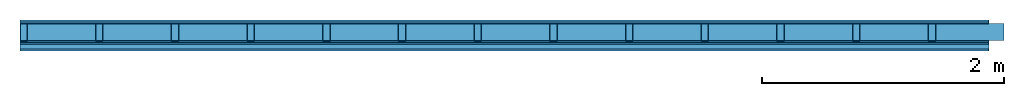
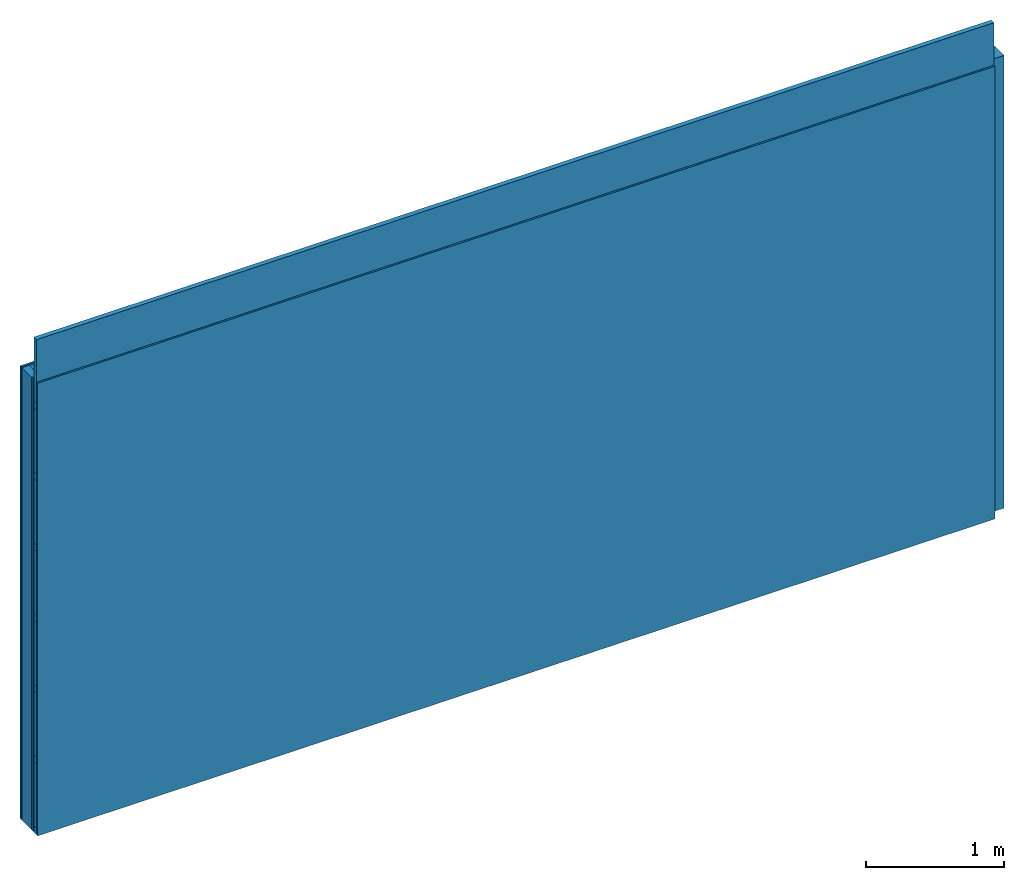
# One storey: 5 plates, 4 members, 1 element without a shape of its own.
"""IFC4 building model written with IfcOpenShell, lengths in metres."""

from ifc_helpers import new_model, si_unit, derived_unit, direction, frame, frame_2d, origin, origin_with_axes, place, context, project, spatial, rectangle, extrude, material, layer, layer_set, type_object, element, aggregate, save


model = new_model("IFC4")

# Units and contexts
plan_context = context("Plan", 3, precision=1e-05, world=origin(), true_north=direction((0.0, 1.0)))
model_context = context("Model", 3, precision=1e-05, world=origin(), true_north=direction((0.0, 1.0)))
ifc_project = project(units=[si_unit("LENGTHUNIT", "METRE"), derived_unit("SOUNDPRESSUREUNIT", [(si_unit("PRESSUREUNIT", "PASCAL", prefix="MICRO"), 0)]), si_unit("ENERGYUNIT", "JOULE", prefix="MEGA"), si_unit("MASSUNIT", "GRAM", prefix="KILO"), derived_unit("THERMALTRANSMITTANCEUNIT", [(si_unit("POWERUNIT", "WATT"), 1), (si_unit("AREAUNIT", "SQUARE_METRE"), -1), (si_unit("THERMODYNAMICTEMPERATUREUNIT", "KELVIN"), -1)]), derived_unit("AREADENSITYUNIT", [(si_unit("MASSUNIT", "GRAM", prefix="KILO"), 1), (si_unit("AREAUNIT", "SQUARE_METRE"), -1)]), derived_unit("USERDEFINED", [(si_unit("ENERGYUNIT", "JOULE", prefix="MEGA"), 1), (si_unit("AREAUNIT", "SQUARE_METRE"), -1)])], contexts=[plan_context, model_context])

# Site, building, storey
site = spatial("IfcSite", under=ifc_project)
building_placement = place(None, origin())
building = spatial("IfcBuilding", under=site, at=building_placement)
storey_placement = place(building_placement, origin())
storey = spatial("IfcBuildingStorey", under=building, at=storey_placement)

# Wall, members, plates
ifc_material_1 = material(Name="Glued joints")
ifc_layer_1 = layer(ifc_material_1, 0.0, Name="Surface")
ifc_material_2 = material(Category="03.007")
ifc_layer_2 = layer(ifc_material_2, 0.015, Name="2nd layer")
ifc_layer_3 = layer(ifc_material_2, 0.015, Name="1st layer")
ifc_material_3 = material(Name="of the art")
ifc_layer_4 = layer(ifc_material_3, 0.0, Name="Bond")
ifc_layer_5 = layer(None, 0.14, Name="Support")
ifc_layer_6 = layer(ifc_material_3, 0.0, Name="Bond")
ifc_layer_7 = layer(ifc_material_2, 0.015, Name="1st layer")
ifc_layer_8 = layer(ifc_material_2, 0.015, Name="2nd layer")
ifc_material_4 = material(Name="Substructure rigid")
ifc_layer_9 = layer(ifc_material_4, 0.0, Name="Coupling")
ifc_layer_10 = layer(None, 0.04, Name="Battens / profiles")
ifc_layer_11 = layer(ifc_material_2, 0.015, Name="Covering 1st layer")
ifc_layer_12 = layer(ifc_material_1, 0.0, Name="Surface")
ifc_layer_set = layer_set([ifc_layer_1, ifc_layer_2, ifc_layer_3, ifc_layer_4, ifc_layer_5, ifc_layer_6, ifc_layer_7, ifc_layer_8, ifc_layer_9, ifc_layer_10, ifc_layer_11, ifc_layer_12])
wall_type = type_object("IfcWallType", Name="C0088", PredefinedType="NOTDEFINED", material=ifc_layer_set)
wall_placement = place(None, frame((0.0, 0.0, 0.0), z_axis=(0.0, -1.0, 0.0), x_axis=(1.0, 0.0, 0.0)))
wall = element("IfcWall", 1, at=wall_placement, inside=storey, type_object=wall_type, material=ifc_layer_set, Name="Wall #1")
ifc_material_5 = material()
member_1_placement = place(wall_placement, origin())
member_1 = element("IfcMember", 2, at=member_1_placement, material=ifc_material_5, Name="Support", context=plan_context, shape_type="SweptSolid", body=[
    extrude(rectangle(XDim=0.06, YDim=0.14, at=frame_2d((0.03, 0.07), x_axis=(1.0, 0.0))), frame((0.0, 4.0, 0.03), z_axis=(0.0, -1.0, 0.0), x_axis=(1.0, 0.0, 0.0)), (0.0, 0.0, 1.0), 4.0),
    extrude(rectangle(XDim=0.06, YDim=0.14, at=frame_2d((0.03, 0.07), x_axis=(1.0, 0.0))), frame((0.625, 4.0, 0.03), z_axis=(0.0, -1.0, 0.0), x_axis=(1.0, 0.0, 0.0)), (0.0, 0.0, 1.0), 4.0),
    extrude(rectangle(XDim=0.06, YDim=0.14, at=frame_2d((0.03, 0.07), x_axis=(1.0, 0.0))), frame((1.25, 4.0, 0.03), z_axis=(0.0, -1.0, 0.0), x_axis=(1.0, 0.0, 0.0)), (0.0, 0.0, 1.0), 4.0),
    extrude(rectangle(XDim=0.06, YDim=0.14, at=frame_2d((0.03, 0.07), x_axis=(1.0, 0.0))), frame((1.875, 4.0, 0.03), z_axis=(0.0, -1.0, 0.0), x_axis=(1.0, 0.0, 0.0)), (0.0, 0.0, 1.0), 4.0),
    extrude(rectangle(XDim=0.06, YDim=0.14, at=frame_2d((0.03, 0.07), x_axis=(1.0, 0.0))), frame((2.5, 4.0, 0.03), z_axis=(0.0, -1.0, 0.0), x_axis=(1.0, 0.0, 0.0)), (0.0, 0.0, 1.0), 4.0),
    extrude(rectangle(XDim=0.06, YDim=0.14, at=frame_2d((0.03, 0.07), x_axis=(1.0, 0.0))), frame((3.125, 4.0, 0.03), z_axis=(0.0, -1.0, 0.0), x_axis=(1.0, 0.0, 0.0)), (0.0, 0.0, 1.0), 4.0),
    extrude(rectangle(XDim=0.06, YDim=0.14, at=frame_2d((0.03, 0.07), x_axis=(1.0, 0.0))), frame((3.75, 4.0, 0.03), z_axis=(0.0, -1.0, 0.0), x_axis=(1.0, 0.0, 0.0)), (0.0, 0.0, 1.0), 4.0),
    extrude(rectangle(XDim=0.06, YDim=0.14, at=frame_2d((0.03, 0.07), x_axis=(1.0, 0.0))), frame((4.375, 4.0, 0.03), z_axis=(0.0, -1.0, 0.0), x_axis=(1.0, 0.0, 0.0)), (0.0, 0.0, 1.0), 4.0),
    extrude(rectangle(XDim=0.06, YDim=0.14, at=frame_2d((0.03, 0.07), x_axis=(1.0, 0.0))), frame((5.0, 4.0, 0.03), z_axis=(0.0, -1.0, 0.0), x_axis=(1.0, 0.0, 0.0)), (0.0, 0.0, 1.0), 4.0),
    extrude(rectangle(XDim=0.06, YDim=0.14, at=frame_2d((0.03, 0.07), x_axis=(1.0, 0.0))), frame((5.625, 4.0, 0.03), z_axis=(0.0, -1.0, 0.0), x_axis=(1.0, 0.0, 0.0)), (0.0, 0.0, 1.0), 4.0),
    extrude(rectangle(XDim=0.06, YDim=0.14, at=frame_2d((0.03, 0.07), x_axis=(1.0, 0.0))), frame((6.25, 4.0, 0.03), z_axis=(0.0, -1.0, 0.0), x_axis=(1.0, 0.0, 0.0)), (0.0, 0.0, 1.0), 4.0),
    extrude(rectangle(XDim=0.06, YDim=0.14, at=frame_2d((0.03, 0.07), x_axis=(1.0, 0.0))), frame((6.875, 4.0, 0.03), z_axis=(0.0, -1.0, 0.0), x_axis=(1.0, 0.0, 0.0)), (0.0, 0.0, 1.0), 4.0),
    extrude(rectangle(XDim=0.06, YDim=0.14, at=frame_2d((0.03, 0.07), x_axis=(1.0, 0.0))), frame((7.5, 4.0, 0.03), z_axis=(0.0, -1.0, 0.0), x_axis=(1.0, 0.0, 0.0)), (0.0, 0.0, 1.0), 4.0),
])
ifc_material_6 = material()
member_2_placement = place(wall_placement, origin())
member_2 = element("IfcMember", 3, at=member_2_placement, material=ifc_material_6, Name="Cavity", context=plan_context, shape_type="SweptSolid", body=[
    extrude(rectangle(XDim=0.565, YDim=0.14, at=frame_2d((0.2825, 0.07), x_axis=(1.0, 0.0))), frame((0.06, 4.0, 0.03), z_axis=(0.0, -1.0, 0.0), x_axis=(1.0, 0.0, 0.0)), (0.0, 0.0, 1.0), 4.0),
    extrude(rectangle(XDim=0.565, YDim=0.14, at=frame_2d((0.2825, 0.07), x_axis=(1.0, 0.0))), frame((0.685, 4.0, 0.03), z_axis=(0.0, -1.0, 0.0), x_axis=(1.0, 0.0, 0.0)), (0.0, 0.0, 1.0), 4.0),
    extrude(rectangle(XDim=0.565, YDim=0.14, at=frame_2d((0.2825, 0.07), x_axis=(1.0, 0.0))), frame((1.31, 4.0, 0.03), z_axis=(0.0, -1.0, 0.0), x_axis=(1.0, 0.0, 0.0)), (0.0, 0.0, 1.0), 4.0),
    extrude(rectangle(XDim=0.565, YDim=0.14, at=frame_2d((0.2825, 0.07), x_axis=(1.0, 0.0))), frame((1.935, 4.0, 0.03), z_axis=(0.0, -1.0, 0.0), x_axis=(1.0, 0.0, 0.0)), (0.0, 0.0, 1.0), 4.0),
    extrude(rectangle(XDim=0.565, YDim=0.14, at=frame_2d((0.2825, 0.07), x_axis=(1.0, 0.0))), frame((2.56, 4.0, 0.03), z_axis=(0.0, -1.0, 0.0), x_axis=(1.0, 0.0, 0.0)), (0.0, 0.0, 1.0), 4.0),
    extrude(rectangle(XDim=0.565, YDim=0.14, at=frame_2d((0.2825, 0.07), x_axis=(1.0, 0.0))), frame((3.185, 4.0, 0.03), z_axis=(0.0, -1.0, 0.0), x_axis=(1.0, 0.0, 0.0)), (0.0, 0.0, 1.0), 4.0),
    extrude(rectangle(XDim=0.565, YDim=0.14, at=frame_2d((0.2825, 0.07), x_axis=(1.0, 0.0))), frame((3.81, 4.0, 0.03), z_axis=(0.0, -1.0, 0.0), x_axis=(1.0, 0.0, 0.0)), (0.0, 0.0, 1.0), 4.0),
    extrude(rectangle(XDim=0.565, YDim=0.14, at=frame_2d((0.2825, 0.07), x_axis=(1.0, 0.0))), frame((4.435, 4.0, 0.03), z_axis=(0.0, -1.0, 0.0), x_axis=(1.0, 0.0, 0.0)), (0.0, 0.0, 1.0), 4.0),
    extrude(rectangle(XDim=0.565, YDim=0.14, at=frame_2d((0.2825, 0.07), x_axis=(1.0, 0.0))), frame((5.06, 4.0, 0.03), z_axis=(0.0, -1.0, 0.0), x_axis=(1.0, 0.0, 0.0)), (0.0, 0.0, 1.0), 4.0),
    extrude(rectangle(XDim=0.565, YDim=0.14, at=frame_2d((0.2825, 0.07), x_axis=(1.0, 0.0))), frame((5.685, 4.0, 0.03), z_axis=(0.0, -1.0, 0.0), x_axis=(1.0, 0.0, 0.0)), (0.0, 0.0, 1.0), 4.0),
    extrude(rectangle(XDim=0.565, YDim=0.14, at=frame_2d((0.2825, 0.07), x_axis=(1.0, 0.0))), frame((6.31, 4.0, 0.03), z_axis=(0.0, -1.0, 0.0), x_axis=(1.0, 0.0, 0.0)), (0.0, 0.0, 1.0), 4.0),
    extrude(rectangle(XDim=0.565, YDim=0.14, at=frame_2d((0.2825, 0.07), x_axis=(1.0, 0.0))), frame((6.935, 4.0, 0.03), z_axis=(0.0, -1.0, 0.0), x_axis=(1.0, 0.0, 0.0)), (0.0, 0.0, 1.0), 4.0),
    extrude(rectangle(XDim=0.565, YDim=0.14, at=frame_2d((0.2825, 0.07), x_axis=(1.0, 0.0))), frame((7.56, 4.0, 0.03), z_axis=(0.0, -1.0, 0.0), x_axis=(1.0, 0.0, 0.0)), (0.0, 0.0, 1.0), 4.0),
])
ifc_material_7 = material()
member_3_placement = place(wall_placement, origin())
member_3 = element("IfcMember", 4, at=member_3_placement, material=ifc_material_7, Name="Battens / profiles", context=plan_context, shape_type="SweptSolid", body=[
    extrude(rectangle(XDim=0.06, YDim=0.04, at=frame_2d((0.03, 0.02), x_axis=(1.0, 0.0))), frame((0.0, 0.0, 0.2), z_axis=(1.0, 0.0, 0.0), x_axis=(0.0, 1.0, 0.0)), (0.0, 0.0, 1.0), 8.0),
    extrude(rectangle(XDim=0.06, YDim=0.04, at=frame_2d((0.03, 0.02), x_axis=(1.0, 0.0))), frame((0.0, 0.625, 0.2), z_axis=(1.0, 0.0, 0.0), x_axis=(0.0, 1.0, 0.0)), (0.0, 0.0, 1.0), 8.0),
    extrude(rectangle(XDim=0.06, YDim=0.04, at=frame_2d((0.03, 0.02), x_axis=(1.0, 0.0))), frame((0.0, 1.25, 0.2), z_axis=(1.0, 0.0, 0.0), x_axis=(0.0, 1.0, 0.0)), (0.0, 0.0, 1.0), 8.0),
    extrude(rectangle(XDim=0.06, YDim=0.04, at=frame_2d((0.03, 0.02), x_axis=(1.0, 0.0))), frame((0.0, 1.875, 0.2), z_axis=(1.0, 0.0, 0.0), x_axis=(0.0, 1.0, 0.0)), (0.0, 0.0, 1.0), 8.0),
    extrude(rectangle(XDim=0.06, YDim=0.04, at=frame_2d((0.03, 0.02), x_axis=(1.0, 0.0))), frame((0.0, 2.5, 0.2), z_axis=(1.0, 0.0, 0.0), x_axis=(0.0, 1.0, 0.0)), (0.0, 0.0, 1.0), 8.0),
    extrude(rectangle(XDim=0.06, YDim=0.04, at=frame_2d((0.03, 0.02), x_axis=(1.0, 0.0))), frame((0.0, 3.125, 0.2), z_axis=(1.0, 0.0, 0.0), x_axis=(0.0, 1.0, 0.0)), (0.0, 0.0, 1.0), 8.0),
    extrude(rectangle(XDim=0.06, YDim=0.04, at=frame_2d((0.03, 0.02), x_axis=(1.0, 0.0))), frame((0.0, 3.75, 0.2), z_axis=(1.0, 0.0, 0.0), x_axis=(0.0, 1.0, 0.0)), (0.0, 0.0, 1.0), 8.0),
])
member_4_placement = place(wall_placement, origin())
member_4 = element("IfcMember", 5, at=member_4_placement, material=ifc_material_6, Name="Cavity", context=plan_context, shape_type="SweptSolid", body=[
    extrude(rectangle(XDim=0.565, YDim=0.04, at=frame_2d((0.2825, 0.02), x_axis=(1.0, 0.0))), frame((0.0, 0.06, 0.2), z_axis=(1.0, 0.0, 0.0), x_axis=(0.0, 1.0, 0.0)), (0.0, 0.0, 1.0), 8.0),
    extrude(rectangle(XDim=0.565, YDim=0.04, at=frame_2d((0.2825, 0.02), x_axis=(1.0, 0.0))), frame((0.0, 0.685, 0.2), z_axis=(1.0, 0.0, 0.0), x_axis=(0.0, 1.0, 0.0)), (0.0, 0.0, 1.0), 8.0),
    extrude(rectangle(XDim=0.565, YDim=0.04, at=frame_2d((0.2825, 0.02), x_axis=(1.0, 0.0))), frame((0.0, 1.31, 0.2), z_axis=(1.0, 0.0, 0.0), x_axis=(0.0, 1.0, 0.0)), (0.0, 0.0, 1.0), 8.0),
    extrude(rectangle(XDim=0.565, YDim=0.04, at=frame_2d((0.2825, 0.02), x_axis=(1.0, 0.0))), frame((0.0, 1.935, 0.2), z_axis=(1.0, 0.0, 0.0), x_axis=(0.0, 1.0, 0.0)), (0.0, 0.0, 1.0), 8.0),
    extrude(rectangle(XDim=0.565, YDim=0.04, at=frame_2d((0.2825, 0.02), x_axis=(1.0, 0.0))), frame((0.0, 2.56, 0.2), z_axis=(1.0, 0.0, 0.0), x_axis=(0.0, 1.0, 0.0)), (0.0, 0.0, 1.0), 8.0),
    extrude(rectangle(XDim=0.565, YDim=0.04, at=frame_2d((0.2825, 0.02), x_axis=(1.0, 0.0))), frame((0.0, 3.185, 0.2), z_axis=(1.0, 0.0, 0.0), x_axis=(0.0, 1.0, 0.0)), (0.0, 0.0, 1.0), 8.0),
    extrude(rectangle(XDim=0.565, YDim=0.04, at=frame_2d((0.2825, 0.02), x_axis=(1.0, 0.0))), frame((0.0, 3.81, 0.2), z_axis=(1.0, 0.0, 0.0), x_axis=(0.0, 1.0, 0.0)), (0.0, 0.0, 1.0), 8.0),
])
plate_1_placement = place(wall_placement, origin())
plate_1 = element("IfcPlate", 6, at=plate_1_placement, material=ifc_material_2, Name="2nd layer", context=plan_context, shape_type="SweptSolid", body=[
    extrude(rectangle(XDim=8.0, YDim=4.0, at=frame_2d((4.0, 2.0), x_axis=(1.0, 0.0))), origin_with_axes(), (0.0, 0.0, 1.0), 0.015),
])
plate_2_placement = place(wall_placement, origin())
plate_2 = element("IfcPlate", 7, at=plate_2_placement, material=ifc_material_2, Name="1st layer", context=plan_context, shape_type="SweptSolid", body=[
    extrude(rectangle(XDim=8.0, YDim=4.0, at=frame_2d((4.0, 2.0), x_axis=(1.0, 0.0))), frame((0.0, 0.0, 0.015), z_axis=(0.0, 0.0, 1.0), x_axis=(1.0, 0.0, 0.0)), (0.0, 0.0, 1.0), 0.015),
])
plate_3_placement = place(wall_placement, origin())
plate_3 = element("IfcPlate", 8, at=plate_3_placement, material=ifc_material_2, Name="1st layer", context=plan_context, shape_type="SweptSolid", body=[
    extrude(rectangle(XDim=8.0, YDim=4.0, at=frame_2d((4.0, 2.0), x_axis=(1.0, 0.0))), frame((0.0, 0.0, 0.17), z_axis=(0.0, 0.0, 1.0), x_axis=(1.0, 0.0, 0.0)), (0.0, 0.0, 1.0), 0.015),
])
plate_4_placement = place(wall_placement, origin())
plate_4 = element("IfcPlate", 9, at=plate_4_placement, material=ifc_material_2, Name="2nd layer", context=plan_context, shape_type="SweptSolid", body=[
    extrude(rectangle(XDim=8.0, YDim=4.0, at=frame_2d((4.0, 2.0), x_axis=(1.0, 0.0))), frame((0.0, 0.0, 0.185), z_axis=(0.0, 0.0, 1.0), x_axis=(1.0, 0.0, 0.0)), (0.0, 0.0, 1.0), 0.015),
])
plate_5_placement = place(wall_placement, origin())
plate_5 = element("IfcPlate", 10, at=plate_5_placement, material=ifc_material_2, Name="Covering 1st layer", context=plan_context, shape_type="SweptSolid", body=[
    extrude(rectangle(XDim=8.0, YDim=4.0, at=frame_2d((4.0, 2.0), x_axis=(1.0, 0.0))), frame((0.0, 0.0, 0.24), z_axis=(0.0, 0.0, 1.0), x_axis=(1.0, 0.0, 0.0)), (0.0, 0.0, 1.0), 0.015),
])
aggregate(wall, [plate_1, plate_2, member_1, member_2, plate_3, plate_4, member_3, member_4, plate_5])

save(model, "model.ifc")
